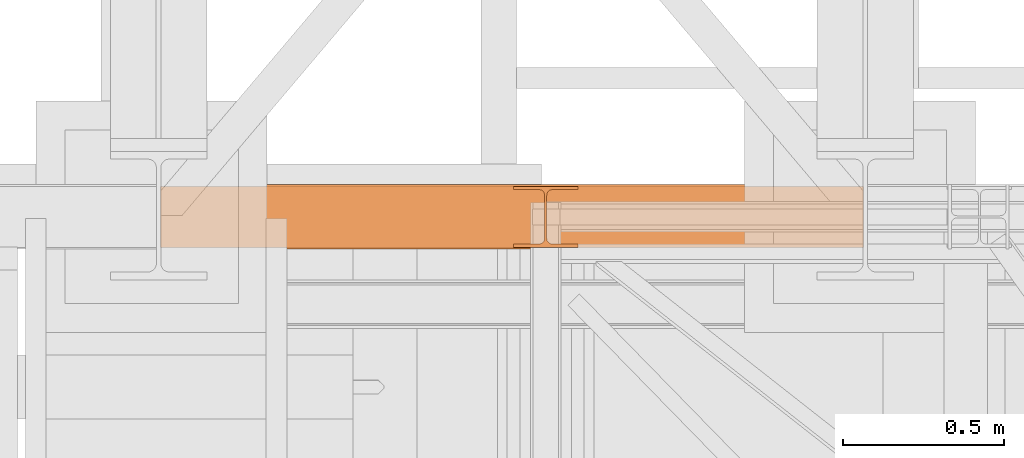
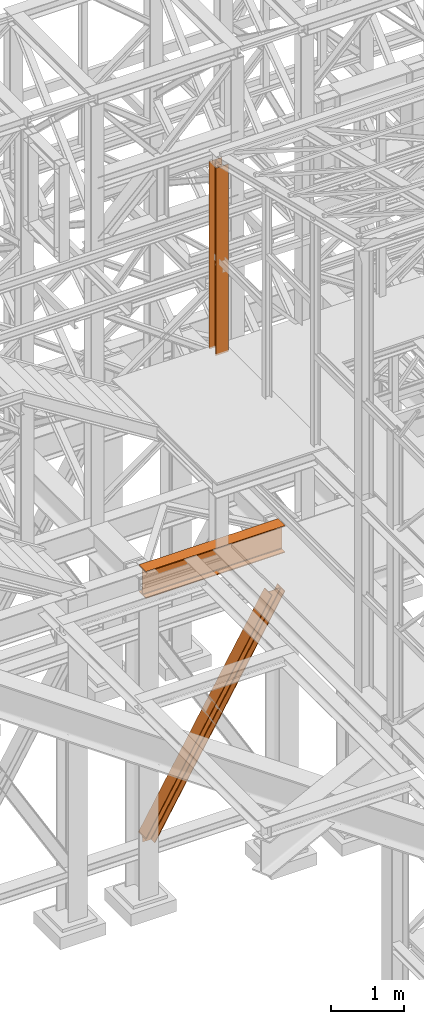
# One storey, part 33 of 208: 3 proxies.
"""IFC2X3 building model written with IfcOpenShell, lengths in millimetres."""

from ifc_helpers import new_model, entity, si_unit, converted_unit, frame, origin, origin_with_axes, place, context, subcontext, project, spatial, faceted_brep, element, save


model = new_model("IFC2X3")

# Units and contexts
model_context = context("Model", 3, precision=1e-05, world=origin())
plan_context = context("Plan", 3, precision=1e-05, world=origin())
body_context = subcontext(model_context, "Body", "Model", "MODEL_VIEW")
ifc_project = project(units=[si_unit("LENGTHUNIT", "METRE", prefix="MILLI"), converted_unit("PLANEANGLEUNIT", "DEGREE", entity("IfcPlaneAngleMeasure", 0.0174532925199433), si_unit("PLANEANGLEUNIT", "RADIAN"), dimensions=[0, 0, 0, 0, 0, 0, 0]), si_unit("AREAUNIT", "SQUARE_METRE"), si_unit("VOLUMEUNIT", "CUBIC_METRE")], contexts=[model_context, plan_context])

# Building, storey
building_placement = place(None, origin())
building = spatial("IfcBuilding", under=ifc_project, at=building_placement, CompositionType="COMPLEX")
storey_placement = place(building_placement, origin_with_axes())
storey = spatial("IfcBuildingStorey", under=building, at=storey_placement, Name="Geschoss", CompositionType="ELEMENT")

# Proxies
proxy_1_placement = place(storey_placement, frame((0.004889571831199646, -17362.5323246858, 734.9900149335328), z_axis=(0.0, 0.0, 1.0), x_axis=(1.0, 0.0, 0.0)))
element("IfcBuildingElementProxy", 1, at=proxy_1_placement, inside=storey, context=body_context, shape_type="Brep", body=[
    faceted_brep([(0.0100850216138042, 0.00999999999839929, 120.8497915510925), (0.0100850216138042, 200.0100029802306, 120.8497915510925), (1970.595410063094, 200.0100029802306, 3468.009977913908), (1970.595410063094, 0.00999999999839929, 3468.009977913908), (0.0100850216138042, 200.0100029802306, 120.8497915510925), (0.01008502161334945, 200.0100029802306, 101.4682129393399), (1982.007890767009, 200.0100029802306, 3468.009977913908), (1970.595410063094, 200.0100029802306, 3468.009977913908), (0.01008502161334945, 200.0100029802306, 101.4682129393399), (0.01008502127456268, 121.2600035762771, 101.4681984983712), (1982.007899269972, 121.2600035762771, 3468.009977913908), (1982.007890767009, 200.0100029802306, 3468.009977913908), (0.01008502127456268, 121.2600035762771, 101.4681984983712), (0.009999999999990905, 111.9441915473326, 97.8542740943027), (1984.135808151259, 111.9441915473326, 3468.009977913909), (1982.007899269972, 121.2600035762771, 3468.009977913908), (0.009999999999990905, 111.9441915473326, 97.8542740943027), (0.0100850216138042, 105.1245498640819, 84.63689245399053), (1991.918714280976, 105.1245498640819, 3468.009977913908), (1984.135808151259, 111.9441915473326, 3468.009977913909), (0.0100850216138042, 105.1245498640819, 84.63689245399053), (0.0100850216138042, 103.2600015571697, 66.58142866151934), (2002.550367938205, 103.2600015571697, 3468.009977913908), (1991.918714280976, 105.1245498640819, 3468.009977913908), (0.0100850216138042, 103.2600015571697, 0.01000000000010459), (113.7187158034401, 103.2600015571697, 0.01000000000033197), (2155.477653586077, 103.2600015571697, 3468.009977913908), (2002.550367938205, 103.2600015571697, 3468.009977913908), (0.0100850216138042, 103.2600015571697, 66.58142866151934), (113.7187158034401, 103.2600015571697, 0.01000000000033197), (124.3486060538469, 105.1245498640819, 0.01000000000021828), (2166.109307243306, 105.1245498640819, 3468.009977913908), (2155.477653586077, 103.2600015571697, 3468.009977913908), (124.3486060538469, 105.1245498640819, 0.01000000000021828), (132.1302232850383, 111.9441915473326, 0.009999999999877218), (2173.892213373023, 111.9441915473326, 3468.009977913908), (2166.109307243306, 105.1245498640819, 3468.009977913908), (132.1302232850383, 111.9441915473326, 0.009999999999877218), (134.257780065537, 121.2600035762771, 0.009999999999877218), (2176.020122254309, 121.2600035762771, 3468.009977913907), (2173.892213373023, 111.9441915473326, 3468.009977913908), (134.257780065537, 121.2600035762771, 0.009999999999877218), (134.257780065537, 200.0100029802306, 0.009999999999877218), (2176.020122254309, 200.0100029802306, 3468.009977913907), (2176.020122254309, 121.2600035762771, 3468.009977913907), (134.257780065537, 200.0100029802306, 0.009999999999877218), (145.6683745225666, 200.0100029802306, 0.01000000000010459), (2187.432602958225, 200.0100029802306, 3468.009977913908), (2176.020122254309, 200.0100029802306, 3468.009977913907), (145.6683745225666, 200.0100029802306, 0.01000000000010459), (145.6683745225666, 0.00999999999839929, 0.01000000000010459), (2187.432602958225, 0.00999999999839929, 3468.009977913908), (2187.432602958225, 200.0100029802306, 3468.009977913908), (145.6683745225666, 0.00999999999839929, 0.01000000000010459), (134.257780065537, 0.00999999999839929, 0.009999999999990905), (2176.020122254308, 0.00999999999839929, 3468.009977913908), (2187.432602958225, 0.00999999999839929, 3468.009977913908), (134.257780065537, 0.00999999999839929, 0.009999999999990905), (134.257780065537, 78.75999940395195, 0.009999999999877218), (2176.020122254309, 78.75999940395195, 3468.009977913907), (2176.020122254308, 0.00999999999839929, 3468.009977913908), (134.257780065537, 78.75999940395195, 0.009999999999877218), (132.1302232850383, 88.07581143289644, 0.009999999999877218), (2173.892213373023, 88.07581143290008, 3468.009977913908), (2176.020122254309, 78.75999940395195, 3468.009977913907), (132.1302232850383, 88.07581143289644, 0.009999999999877218), (124.3486060538464, 94.89545311614711, 0.009999999999877218), (2166.109307243306, 94.89545311614711, 3468.009977913908), (2173.892213373023, 88.07581143290008, 3468.009977913908), (124.3486060538464, 94.89545311614711, 0.009999999999877218), (113.7187158034401, 96.7600014230593, 0.01000000000033197), (2155.477653586077, 96.7600014230593, 3468.009977913908), (2166.109307243306, 94.89545311614711, 3468.009977913908), (113.7187158034401, 96.7600014230593, 0.01000000000033197), (0.01008502161334945, 96.7600014230593, 0.01000000000010459), (0.0100850216138042, 96.7600014230593, 66.581428661519), (2002.550367938205, 96.7600014230593, 3468.009977913908), (2155.477653586077, 96.7600014230593, 3468.009977913908), (0.0100850216138042, 96.7600014230593, 66.581428661519), (0.0100850216138042, 94.89545311615075, 84.63689245399053), (1991.918714280976, 94.89545311614711, 3468.009977913908), (2002.550367938205, 96.7600014230593, 3468.009977913908), (0.0100850216138042, 94.89545311615075, 84.63689245399053), (0.0100850216138042, 88.07581143289644, 97.85441850857103), (1984.135808151259, 88.07581143289644, 3468.009977913909), (1991.918714280976, 94.89545311614711, 3468.009977913908), (0.0100850216138042, 88.07581143289644, 97.85441850857103), (0.01016988589049106, 78.75999940395195, 101.4683426459952), (1982.007899269971, 78.75999940395195, 3468.009977913908), (1984.135808151259, 88.07581143289644, 3468.009977913909), (0.01016988589049106, 78.75999940395195, 101.4683426459952), (0.01008502195304573, 0.00999999999839929, 101.4682129399165), (1982.007890767009, 0.00999999999839929, 3468.009977913908), (1982.007899269971, 78.75999940395195, 3468.009977913908), (0.01008502195304573, 0.00999999999839929, 101.4682129399165), (0.0100850216138042, 0.00999999999839929, 120.8497915510925), (1970.595410063094, 0.00999999999839929, 3468.009977913908), (1982.007890767009, 0.00999999999839929, 3468.009977913908), (1970.595410063094, 0.00999999999839929, 3468.009977913908), (1970.595410063094, 200.0100029802306, 3468.009977913908), (1982.007890767009, 200.0100029802306, 3468.009977913908), (1982.007899269972, 121.2600035762771, 3468.009977913908), (1984.135808151259, 111.9441915473326, 3468.009977913909), (1991.918714280976, 105.1245498640819, 3468.009977913908), (2002.550367938205, 103.2600015571697, 3468.009977913908), (2155.477653586077, 103.2600015571697, 3468.009977913908), (2166.109307243306, 105.1245498640819, 3468.009977913908), (2173.892213373023, 111.9441915473326, 3468.009977913908), (2176.020122254309, 121.2600035762771, 3468.009977913907), (2176.020122254309, 200.0100029802306, 3468.009977913907), (2187.432602958225, 200.0100029802306, 3468.009977913908), (2187.432602958225, 0.00999999999839929, 3468.009977913908), (2176.020122254308, 0.00999999999839929, 3468.009977913908), (2176.020122254309, 78.75999940395195, 3468.009977913907), (2173.892213373023, 88.07581143290008, 3468.009977913908), (2166.109307243306, 94.89545311614711, 3468.009977913908), (2155.477653586077, 96.7600014230593, 3468.009977913908), (2002.550367938205, 96.7600014230593, 3468.009977913908), (1991.918714280976, 94.89545311614711, 3468.009977913908), (1984.135808151259, 88.07581143289644, 3468.009977913909), (1982.007899269971, 78.75999940395195, 3468.009977913908), (1982.007890767009, 0.00999999999839929, 3468.009977913908), (0.01008502161334945, 96.7600014230593, 0.01000000000010459), (0.0100850216138042, 103.2600015571697, 0.01000000000010459), (0.0100850216138042, 103.2600015571697, 66.58142866151934), (0.0100850216138042, 105.1245498640819, 84.63689245399053), (0.009999999999990905, 111.9441915473326, 97.8542740943027), (0.01008502127456268, 121.2600035762771, 101.4681984983712), (0.01008502161334945, 200.0100029802306, 101.4682129393399), (0.0100850216138042, 200.0100029802306, 120.8497915510925), (0.0100850216138042, 0.00999999999839929, 120.8497915510925), (0.01008502195304573, 0.00999999999839929, 101.4682129399165), (0.01016988589049106, 78.75999940395195, 101.4683426459952), (0.0100850216138042, 88.07581143289644, 97.85441850857103), (0.0100850216138042, 94.89545311615075, 84.63689245399053), (0.0100850216138042, 96.7600014230593, 66.581428661519), (113.7187158034401, 103.2600015571697, 0.01000000000033197), (0.0100850216138042, 103.2600015571697, 0.01000000000010459), (0.01008502161334945, 96.7600014230593, 0.01000000000010459), (113.7187158034401, 96.7600014230593, 0.01000000000033197), (124.3486060538464, 94.89545311614711, 0.009999999999877218), (132.1302232850383, 88.07581143289644, 0.009999999999877218), (134.257780065537, 78.75999940395195, 0.009999999999877218), (134.257780065537, 0.00999999999839929, 0.009999999999990905), (145.6683745225666, 0.00999999999839929, 0.01000000000010459), (145.6683745225666, 200.0100029802306, 0.01000000000010459), (134.257780065537, 200.0100029802306, 0.009999999999877218), (134.257780065537, 121.2600035762771, 0.009999999999877218), (132.1302232850383, 111.9441915473326, 0.009999999999877218), (124.3486060538469, 105.1245498640819, 0.01000000000021828)], [[[0, 1, 2, 3]], [[4, 5, 6, 7]], [[8, 9, 10, 11]], [[12, 13, 14, 15]], [[16, 17, 18, 19]], [[20, 21, 22, 23]], [[24, 25, 26, 27, 28]], [[29, 30, 31, 32]], [[33, 34, 35, 36]], [[37, 38, 39, 40]], [[41, 42, 43, 44]], [[45, 46, 47, 48]], [[49, 50, 51, 52]], [[53, 54, 55, 56]], [[57, 58, 59, 60]], [[61, 62, 63, 64]], [[65, 66, 67, 68]], [[69, 70, 71, 72]], [[73, 74, 75, 76, 77]], [[78, 79, 80, 81]], [[82, 83, 84, 85]], [[86, 87, 88, 89]], [[90, 91, 92, 93]], [[94, 95, 96, 97]], [[98, 99, 100, 101, 102, 103, 104, 105, 106, 107, 108, 109, 110, 111, 112, 113, 114, 115, 116, 117, 118, 119, 120, 121]], [[122, 123, 124, 125, 126, 127, 128, 129, 130, 131, 132, 133, 134, 135]], [[136, 137, 138, 139, 140, 141, 142, 143, 144, 145, 146, 147, 148, 149]]], orient=[[False], [False], [False], [False], [False], [False], [False], [False], [False], [False], [False], [False], [False], [False], [False], [False], [False], [False], [False], [False], [False], [False], [False], [False], [False], [False], [False]]),
])
proxy_2_placement = place(storey_placement, frame((-0.7450314191753478, -17357.574399786, 4834.989987483023), z_axis=(0.0, 0.0, 1.0), x_axis=(1.0, 0.0, 0.0)))
element("IfcBuildingElementProxy", 2, at=proxy_2_placement, inside=storey, context=body_context, shape_type="Brep", body=[
    faceted_brep([(2188.009999895692, 0.00999999999839929, 450.0100178813937), (2188.009999895692, 190.0100125169738, 450.0100178813937), (2188.009999895692, 190.0100125169738, 435.4100240564349), (2188.009999895692, 120.7100073045476, 435.4100091552737), (2188.009999895692, 109.8415622657522, 433.2347078418734), (2188.009999895692, 101.8853126263603, 425.2784563398363), (2188.009999895692, 99.71000619068582, 414.4100113010409), (2188.009999895692, 99.71000619068582, 35.60999167919181), (2188.009999895692, 101.8853126263603, 24.74154664039634), (2188.009999895692, 109.8415622657522, 16.78529513835929), (2188.009999895692, 120.7100073045476, 14.60999382495902), (2188.009999895692, 190.0100125169738, 14.60999382495902), (2188.009999895692, 190.0100125169738, 0.01000000000021828), (2188.009999895692, 0.00999999999839929, 0.01000000000021828), (2188.009999895692, 0.00999999999839929, 14.60999382495902), (2188.009999895692, 69.31000521242458, 14.60999382495902), (2188.009999895692, 80.17845025122006, 16.78529513835929), (2188.009999895692, 88.13469989061196, 24.74154664039634), (2188.009999895692, 90.31000632628638, 35.60999167919181), (2188.009999895692, 90.31000632628638, 414.4100113010409), (2188.009999895692, 88.13469989061196, 425.2784563398363), (2188.009999895692, 80.17845025122006, 433.2347078418734), (2188.009999895692, 69.31000521242458, 435.4100091552737), (2188.009999895692, 0.00999999999839929, 435.4100240564349), (2188.009999895692, 190.0100125169738, 450.0100178813937), (2188.009999895692, 0.00999999999839929, 450.0100178813937), (0.009999999999990905, 0.00999999999839929, 450.0100178813937), (0.009999999999990905, 190.0100125169738, 450.0100178813937), (2188.009999895692, 190.0100125169738, 435.4100240564349), (2188.009999895692, 190.0100125169738, 450.0100178813937), (0.009999999999990905, 190.0100125169738, 450.0100178813937), (0.009999999999990905, 190.0100125169738, 435.4100240564349), (2188.009999895692, 120.7100073045476, 435.4100091552737), (2188.009999895692, 190.0100125169738, 435.4100240564349), (0.009999999999990905, 190.0100125169738, 435.4100240564349), (0.009999999999990905, 120.7100073045476, 435.4100091552737), (2188.009999895692, 109.8415622657522, 433.2347078418734), (2188.009999895692, 120.7100073045476, 435.4100091552737), (0.009999999999990905, 120.7100073045476, 435.4100091552737), (0.009999999999990905, 109.8415622657522, 433.2347078418734), (2188.009999895692, 101.8853126263603, 425.2784563398363), (2188.009999895692, 109.8415622657522, 433.2347078418734), (0.009999999999990905, 109.8415622657522, 433.2347078418734), (0.009999999999990905, 101.8853126263603, 425.2784563398363), (2188.009999895692, 99.71000619068582, 414.4100113010409), (2188.009999895692, 101.8853126263603, 425.2784563398363), (0.009999999999990905, 101.8853126263603, 425.2784563398363), (0.009999999999990905, 99.71000619068582, 414.4100113010409), (2188.009999895692, 99.71000619068582, 35.60999167919181), (2188.009999895692, 99.71000619068582, 414.4100113010409), (0.009999999999990905, 99.71000619068582, 414.4100113010409), (0.009999999999990905, 99.71000619068582, 35.60999167919181), (2188.009999895692, 101.8853126263603, 24.74154664039634), (2188.009999895692, 99.71000619068582, 35.60999167919181), (0.009999999999990905, 99.71000619068582, 35.60999167919181), (0.009999999999990905, 101.8853126263603, 24.74154664039634), (2188.009999895692, 109.8415622657522, 16.78529513835929), (2188.009999895692, 101.8853126263603, 24.74154664039634), (0.009999999999990905, 101.8853126263603, 24.74154664039634), (0.009999999999990905, 109.8415622657522, 16.78529513835929), (2188.009999895692, 120.7100073045476, 14.60999382495902), (2188.009999895692, 109.8415622657522, 16.78529513835929), (0.009999999999990905, 109.8415622657522, 16.78529513835929), (0.009999999999990905, 120.7100073045476, 14.60999382495902), (2188.009999895692, 190.0100125169738, 14.60999382495902), (2188.009999895692, 120.7100073045476, 14.60999382495902), (0.009999999999990905, 120.7100073045476, 14.60999382495902), (0.009999999999990905, 190.0100125169738, 14.60999382495902), (2188.009999895692, 190.0100125169738, 0.01000000000021828), (2188.009999895692, 190.0100125169738, 14.60999382495902), (0.009999999999990905, 190.0100125169738, 14.60999382495902), (0.009999999999990905, 190.0100125169738, 0.01000000000021828), (2188.009999895692, 0.00999999999839929, 0.01000000000021828), (2188.009999895692, 190.0100125169738, 0.01000000000021828), (0.009999999999990905, 190.0100125169738, 0.01000000000021828), (0.009999999999990905, 0.00999999999839929, 0.01000000000021828), (2188.009999895692, 0.00999999999839929, 14.60999382495902), (2188.009999895692, 0.00999999999839929, 0.01000000000021828), (0.009999999999990905, 0.00999999999839929, 0.01000000000021828), (0.009999999999990905, 0.00999999999839929, 14.60999382495902), (2188.009999895692, 69.31000521242458, 14.60999382495902), (2188.009999895692, 0.00999999999839929, 14.60999382495902), (0.009999999999990905, 0.00999999999839929, 14.60999382495902), (0.009999999999990905, 69.31000521242458, 14.60999382495902), (2188.009999895692, 80.17845025122006, 16.78529513835929), (2188.009999895692, 69.31000521242458, 14.60999382495902), (0.009999999999990905, 69.31000521242458, 14.60999382495902), (0.009999999999990905, 80.17845025122006, 16.78529513835929), (2188.009999895692, 88.13469989061196, 24.74154664039634), (2188.009999895692, 80.17845025122006, 16.78529513835929), (0.009999999999990905, 80.17845025122006, 16.78529513835929), (0.009999999999990905, 88.13469989061196, 24.74154664039634), (2188.009999895692, 90.31000632628638, 35.60999167919181), (2188.009999895692, 88.13469989061196, 24.74154664039634), (0.009999999999990905, 88.13469989061196, 24.74154664039634), (0.009999999999990905, 90.31000632628638, 35.60999167919181), (2188.009999895692, 90.31000632628638, 414.4100113010409), (2188.009999895692, 90.31000632628638, 35.60999167919181), (0.009999999999990905, 90.31000632628638, 35.60999167919181), (0.009999999999990905, 90.31000632628638, 414.4100113010409), (2188.009999895692, 88.13469989061196, 425.2784563398363), (2188.009999895692, 90.31000632628638, 414.4100113010409), (0.009999999999990905, 90.31000632628638, 414.4100113010409), (0.009999999999990905, 88.13469989061196, 425.2784563398363), (2188.009999895692, 80.17845025122006, 433.2347078418734), (2188.009999895692, 88.13469989061196, 425.2784563398363), (0.009999999999990905, 88.13469989061196, 425.2784563398363), (0.009999999999990905, 80.17845025122006, 433.2347078418734), (2188.009999895692, 69.31000521242458, 435.4100091552737), (2188.009999895692, 80.17845025122006, 433.2347078418734), (0.009999999999990905, 80.17845025122006, 433.2347078418734), (0.009999999999990905, 69.31000521242458, 435.4100091552737), (2188.009999895692, 0.00999999999839929, 435.4100240564349), (2188.009999895692, 69.31000521242458, 435.4100091552737), (0.009999999999990905, 69.31000521242458, 435.4100091552737), (0.009999999999990905, 0.00999999999839929, 435.4100240564349), (2188.009999895692, 0.00999999999839929, 450.0100178813937), (2188.009999895692, 0.00999999999839929, 435.4100240564349), (0.009999999999990905, 0.00999999999839929, 435.4100240564349), (0.009999999999990905, 0.00999999999839929, 450.0100178813937), (0.009999999999990905, 0.00999999999839929, 450.0100178813937), (0.009999999999990905, 0.00999999999839929, 435.4100240564349), (0.009999999999990905, 69.31000521242458, 435.4100091552737), (0.009999999999990905, 80.17845025122006, 433.2347078418734), (0.009999999999990905, 88.13469989061196, 425.2784563398363), (0.009999999999990905, 90.31000632628638, 414.4100113010409), (0.009999999999990905, 90.31000632628638, 35.60999167919181), (0.009999999999990905, 88.13469989061196, 24.74154664039634), (0.009999999999990905, 80.17845025122006, 16.78529513835929), (0.009999999999990905, 69.31000521242458, 14.60999382495902), (0.009999999999990905, 0.00999999999839929, 14.60999382495902), (0.009999999999990905, 0.00999999999839929, 0.01000000000021828), (0.009999999999990905, 190.0100125169738, 0.01000000000021828), (0.009999999999990905, 190.0100125169738, 14.60999382495902), (0.009999999999990905, 120.7100073045476, 14.60999382495902), (0.009999999999990905, 109.8415622657522, 16.78529513835929), (0.009999999999990905, 101.8853126263603, 24.74154664039634), (0.009999999999990905, 99.71000619068582, 35.60999167919181), (0.009999999999990905, 99.71000619068582, 414.4100113010409), (0.009999999999990905, 101.8853126263603, 425.2784563398363), (0.009999999999990905, 109.8415622657522, 433.2347078418734), (0.009999999999990905, 120.7100073045476, 435.4100091552737), (0.009999999999990905, 190.0100125169738, 435.4100240564349), (0.009999999999990905, 190.0100125169738, 450.0100178813937)], [[[0, 1, 2, 3, 4, 5, 6, 7, 8, 9, 10, 11, 12, 13, 14, 15, 16, 17, 18, 19, 20, 21, 22, 23]], [[24, 25, 26, 27]], [[28, 29, 30, 31]], [[32, 33, 34, 35]], [[36, 37, 38, 39]], [[40, 41, 42, 43]], [[44, 45, 46, 47]], [[48, 49, 50, 51]], [[52, 53, 54, 55]], [[56, 57, 58, 59]], [[60, 61, 62, 63]], [[64, 65, 66, 67]], [[68, 69, 70, 71]], [[72, 73, 74, 75]], [[76, 77, 78, 79]], [[80, 81, 82, 83]], [[84, 85, 86, 87]], [[88, 89, 90, 91]], [[92, 93, 94, 95]], [[96, 97, 98, 99]], [[100, 101, 102, 103]], [[104, 105, 106, 107]], [[108, 109, 110, 111]], [[112, 113, 114, 115]], [[116, 117, 118, 119]], [[120, 121, 122, 123, 124, 125, 126, 127, 128, 129, 130, 131, 132, 133, 134, 135, 136, 137, 138, 139, 140, 141, 142, 143]]], orient=[[False], [False], [False], [False], [False], [False], [False], [False], [False], [False], [False], [False], [False], [False], [False], [False], [False], [False], [False], [False], [False], [False], [False], [False], [False], [False]]),
])
proxy_3_placement = place(storey_placement, frame((1098.254967038544, -17357.57439657637, 8484.990002086157), z_axis=(0.0, 0.0, 1.0), x_axis=(1.0, 0.0, 0.0)))
element("IfcBuildingElementProxy", 3, at=proxy_3_placement, inside=storey, context=body_context, shape_type="Brep", body=[
    faceted_brep([(0.009999999999990905, 190.010021192018, 3115.0099922514), (200.0100029802322, 190.010021192018, 3115.0099922514), (200.0100029802322, 180.0100232781806, 3115.0099922514), (121.2600035762787, 180.0100158276, 3115.0099922514), (111.9441915473342, 178.1454707803168, 3115.0099922514), (105.1245498640835, 171.3258277000823, 3115.0099922514), (103.2600015571713, 162.0100166024604, 3115.0099922514), (103.2600015571713, 28.01000581401968, 3115.0099922514), (105.1245498640835, 18.69419471639776, 3115.0099922514), (111.9441915473342, 11.87455163616323, 3115.0099922514), (121.2600035762787, 10.01000658888006, 3115.0099922514), (200.0100029802322, 10.01000658888006, 3115.0099922514), (200.0100029802322, 0.01000867504262715, 3115.0099922514), (0.009999999999990905, 0.01000867504262715, 3115.0099922514), (0.009999999999990905, 10.01000658888006, 3115.0099922514), (78.75999940395354, 10.01000658888006, 3115.0099922514), (88.07581143289804, 11.87455163616323, 3115.0099922514), (94.8954531161487, 18.69419471639776, 3115.0099922514), (96.76000142306088, 28.01000581401968, 3115.0099922514), (96.76000142306088, 162.0100166024604, 3115.0099922514), (94.8954531161487, 171.3258277000823, 3115.0099922514), (88.07581143289804, 178.1454707803168, 3115.0099922514), (78.75999940395354, 180.0100158276, 3115.0099922514), (0.009999999999990905, 180.0100232781806, 3115.0099922514), (200.0100029802322, 190.010021192018, 3115.0099922514), (0.009999999999990905, 190.010021192018, 3115.0099922514), (0.009999999999990905, 190.0100125169738, 0.00999999999839929), (200.0100029802322, 190.0100125169738, 0.00999999999839929), (200.0100029802322, 180.0100232781806, 3115.0099922514), (200.0100029802322, 190.010021192018, 3115.0099922514), (200.0100029802322, 190.0100125169738, 0.00999999999839929), (200.0100029802322, 180.0100146031364, 0.00999999999839929), (121.2600035762787, 180.0100158276, 3115.0099922514), (200.0100029802322, 180.0100232781806, 3115.0099922514), (200.0100029802322, 180.0100146031364, 0.00999999999839929), (121.2600035762787, 180.0100071525558, 0.00999999999839929), (111.9441915473342, 178.1454707803168, 3115.0099922514), (121.2600035762787, 180.0100158276, 3115.0099922514), (121.2600035762787, 180.0100071525558, 0.00999999999839929), (111.9441915473342, 178.1454621052726, 0.00999999999839929), (105.1245498640835, 171.3258277000823, 3115.0099922514), (111.9441915473342, 178.1454707803168, 3115.0099922514), (111.9441915473342, 178.1454621052726, 0.00999999999839929), (105.1245498640835, 171.3258190250381, 0.00999999999839929), (103.2600015571713, 162.0100166024604, 3115.0099922514), (105.1245498640835, 171.3258277000823, 3115.0099922514), (105.1245498640835, 171.3258190250381, 0.00999999999839929), (103.2600015571713, 162.0100079274162, 0.00999999999839929), (103.2600015571713, 28.01000581401968, 3115.0099922514), (103.2600015571713, 162.0100166024604, 3115.0099922514), (103.2600015571713, 162.0100079274162, 0.00999999999839929), (103.2600015571713, 28.00999713897545, 0.00999999999839929), (105.1245498640835, 18.69419471639776, 3115.0099922514), (103.2600015571713, 28.01000581401968, 3115.0099922514), (103.2600015571713, 28.00999713897545, 0.00999999999839929), (105.1245498640835, 18.69418604135353, 0.00999999999839929), (111.9441915473342, 11.87455163616323, 3115.0099922514), (105.1245498640835, 18.69419471639776, 3115.0099922514), (105.1245498640835, 18.69418604135353, 0.00999999999839929), (111.9441915473342, 11.87454296111901, 0.00999999999839929), (121.2600035762787, 10.01000658888006, 3115.0099922514), (111.9441915473342, 11.87455163616323, 3115.0099922514), (111.9441915473342, 11.87454296111901, 0.00999999999839929), (121.2600035762787, 10.00999791383583, 0.00999999999839929), (200.0100029802322, 10.01000658888006, 3115.0099922514), (121.2600035762787, 10.01000658888006, 3115.0099922514), (121.2600035762787, 10.00999791383583, 0.00999999999839929), (200.0100029802322, 10.00999791383583, 0.00999999999839929), (200.0100029802322, 0.01000867504262715, 3115.0099922514), (200.0100029802322, 10.01000658888006, 3115.0099922514), (200.0100029802322, 10.00999791383583, 0.00999999999839929), (200.0100029802322, 0.00999999999839929, 0.00999999999839929), (0.009999999999990905, 0.01000867504262715, 3115.0099922514), (200.0100029802322, 0.01000867504262715, 3115.0099922514), (200.0100029802322, 0.00999999999839929, 0.00999999999839929), (0.009999999999990905, 0.00999999999839929, 0.00999999999839929), (0.009999999999990905, 10.01000658888006, 3115.0099922514), (0.009999999999990905, 0.01000867504262715, 3115.0099922514), (0.009999999999990905, 0.00999999999839929, 0.00999999999839929), (0.009999999999990905, 10.00999791383583, 0.00999999999839929), (78.75999940395354, 10.01000658888006, 3115.0099922514), (0.009999999999990905, 10.01000658888006, 3115.0099922514), (0.009999999999990905, 10.00999791383583, 0.00999999999839929), (78.75999940395354, 10.00999791383583, 0.00999999999839929), (88.07581143289804, 11.87455163616323, 3115.0099922514), (78.75999940395354, 10.01000658888006, 3115.0099922514), (78.75999940395354, 10.00999791383583, 0.00999999999839929), (88.07581143289804, 11.87454296111901, 0.00999999999839929), (94.8954531161487, 18.69419471639776, 3115.0099922514), (88.07581143289804, 11.87455163616323, 3115.0099922514), (88.07581143289804, 11.87454296111901, 0.00999999999839929), (94.8954531161487, 18.69418604135353, 0.00999999999839929), (96.76000142306088, 28.01000581401968, 3115.0099922514), (94.8954531161487, 18.69419471639776, 3115.0099922514), (94.8954531161487, 18.69418604135353, 0.00999999999839929), (96.76000142306088, 28.00999713897545, 0.00999999999839929), (96.76000142306088, 162.0100166024604, 3115.0099922514), (96.76000142306088, 28.01000581401968, 3115.0099922514), (96.76000142306088, 28.00999713897545, 0.00999999999839929), (96.76000142306088, 162.0100079274162, 0.00999999999839929), (94.8954531161487, 171.3258277000823, 3115.0099922514), (96.76000142306088, 162.0100166024604, 3115.0099922514), (96.76000142306088, 162.0100079274162, 0.00999999999839929), (94.8954531161487, 171.3258190250381, 0.00999999999839929), (88.07581143289804, 178.1454707803168, 3115.0099922514), (94.8954531161487, 171.3258277000823, 3115.0099922514), (94.8954531161487, 171.3258190250381, 0.00999999999839929), (88.07581143289804, 178.1454621052726, 0.00999999999839929), (78.75999940395354, 180.0100158276, 3115.0099922514), (88.07581143289804, 178.1454707803168, 3115.0099922514), (88.07581143289804, 178.1454621052726, 0.00999999999839929), (78.75999940395354, 180.0100071525558, 0.00999999999839929), (0.009999999999990905, 180.0100232781806, 3115.0099922514), (78.75999940395354, 180.0100158276, 3115.0099922514), (78.75999940395354, 180.0100071525558, 0.00999999999839929), (0.009999999999990905, 180.0100146031364, 0.00999999999839929), (0.009999999999990905, 190.010021192018, 3115.0099922514), (0.009999999999990905, 180.0100232781806, 3115.0099922514), (0.009999999999990905, 180.0100146031364, 0.00999999999839929), (0.009999999999990905, 190.0100125169738, 0.00999999999839929), (0.009999999999990905, 190.0100125169738, 0.00999999999839929), (0.009999999999990905, 180.0100146031364, 0.00999999999839929), (78.75999940395354, 180.0100071525558, 0.00999999999839929), (88.07581143289804, 178.1454621052726, 0.00999999999839929), (94.8954531161487, 171.3258190250381, 0.00999999999839929), (96.76000142306088, 162.0100079274162, 0.00999999999839929), (96.76000142306088, 28.00999713897545, 0.00999999999839929), (94.8954531161487, 18.69418604135353, 0.00999999999839929), (88.07581143289804, 11.87454296111901, 0.00999999999839929), (78.75999940395354, 10.00999791383583, 0.00999999999839929), (0.009999999999990905, 10.00999791383583, 0.00999999999839929), (0.009999999999990905, 0.00999999999839929, 0.00999999999839929), (200.0100029802322, 0.00999999999839929, 0.00999999999839929), (200.0100029802322, 10.00999791383583, 0.00999999999839929), (121.2600035762787, 10.00999791383583, 0.00999999999839929), (111.9441915473342, 11.87454296111901, 0.00999999999839929), (105.1245498640835, 18.69418604135353, 0.00999999999839929), (103.2600015571713, 28.00999713897545, 0.00999999999839929), (103.2600015571713, 162.0100079274162, 0.00999999999839929), (105.1245498640835, 171.3258190250381, 0.00999999999839929), (111.9441915473342, 178.1454621052726, 0.00999999999839929), (121.2600035762787, 180.0100071525558, 0.00999999999839929), (200.0100029802322, 180.0100146031364, 0.00999999999839929), (200.0100029802322, 190.0100125169738, 0.00999999999839929)], [[[0, 1, 2, 3, 4, 5, 6, 7, 8, 9, 10, 11, 12, 13, 14, 15, 16, 17, 18, 19, 20, 21, 22, 23]], [[24, 25, 26, 27]], [[28, 29, 30, 31]], [[32, 33, 34, 35]], [[36, 37, 38, 39]], [[40, 41, 42, 43]], [[44, 45, 46, 47]], [[48, 49, 50, 51]], [[52, 53, 54, 55]], [[56, 57, 58, 59]], [[60, 61, 62, 63]], [[64, 65, 66, 67]], [[68, 69, 70, 71]], [[72, 73, 74, 75]], [[76, 77, 78, 79]], [[80, 81, 82, 83]], [[84, 85, 86, 87]], [[88, 89, 90, 91]], [[92, 93, 94, 95]], [[96, 97, 98, 99]], [[100, 101, 102, 103]], [[104, 105, 106, 107]], [[108, 109, 110, 111]], [[112, 113, 114, 115]], [[116, 117, 118, 119]], [[120, 121, 122, 123, 124, 125, 126, 127, 128, 129, 130, 131, 132, 133, 134, 135, 136, 137, 138, 139, 140, 141, 142, 143]]], orient=[[False], [False], [False], [False], [False], [False], [False], [False], [False], [False], [False], [False], [False], [False], [False], [False], [False], [False], [False], [False], [False], [False], [False], [False], [False], [False]]),
])

save(model, "model.ifc")
